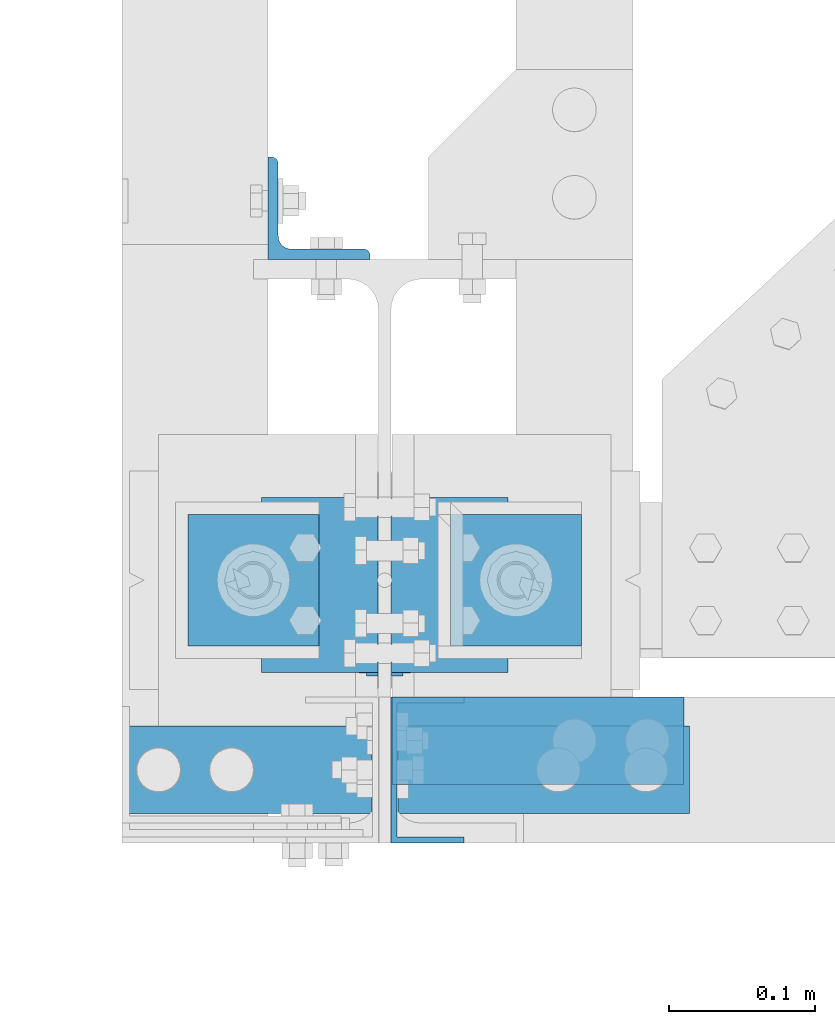
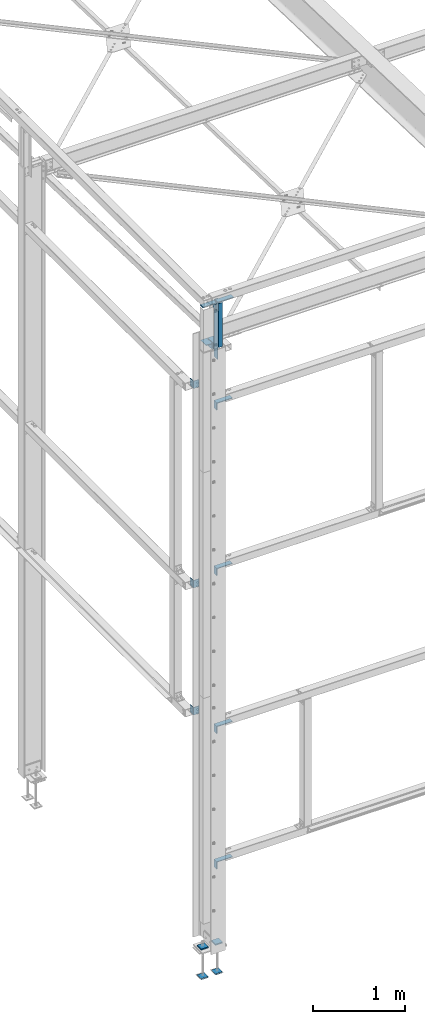
# One storey, part 60 of 496: 16 beams, 13 elements without a shape of their own.
"""IFC2X3 building model written with IfcOpenShell, lengths in millimetres."""

from ifc_helpers import new_model, si_unit, frame, origin_with_axes, origin_2d_with_axis, place, context, subcontext, project, spatial, polyline, l_section, u_section, outline, extrude, boolean, clip, halfspace, material, type_object, element, aggregate, save


model = new_model("IFC2X3")

# Units and contexts
model_context = context("Model", 3, precision=1e-05, world=origin_with_axes())
body_context = subcontext(model_context, "Body", "Model", "MODEL_VIEW")
ifc_project = project(units=[si_unit("LENGTHUNIT", "METRE", prefix="MILLI"), si_unit("AREAUNIT", "SQUARE_METRE"), si_unit("VOLUMEUNIT", "CUBIC_METRE"), si_unit("MASSUNIT", "GRAM", prefix="KILO"), si_unit("TIMEUNIT", "SECOND"), si_unit("PLANEANGLEUNIT", "RADIAN"), si_unit("SOLIDANGLEUNIT", "STERADIAN"), si_unit("THERMODYNAMICTEMPERATUREUNIT", "DEGREE_CELSIUS"), si_unit("LUMINOUSINTENSITYUNIT", "LUMEN")], contexts=[model_context])

# Site, building, storey
site_placement = place(None, origin_with_axes())
site = spatial("IfcSite", under=ifc_project, at=site_placement, CompositionType="ELEMENT")
building_placement = place(site_placement, origin_with_axes())
building = spatial("IfcBuilding", under=site, at=building_placement, Name="Undefined", CompositionType="ELEMENT")
storey_placement = place(building_placement, origin_with_axes())
storey = spatial("IfcBuildingStorey", under=building, at=storey_placement, Name="Undefined", CompositionType="ELEMENT", Elevation=0.0)

# Assembly, beam
assembly_1_placement = place(storey_placement, origin_with_axes())
assembly_1 = element("IfcElementAssembly", 1, at=assembly_1_placement, inside=storey, AssemblyPlace="NOTDEFINED", PredefinedType="NOTDEFINED")
ifc_material = material(Name="Undefined/S235-E24")
beam_type_1 = type_object("IfcBeamType", PredefinedType="NOTDEFINED")
beam_1_placement = place(assembly_1_placement, frame((-44.4999999998312, -64.3677476422468, 7811.91124581093), z_axis=(0.0, -0.031410887010906, -0.999506556345274), x_axis=(0.0, 0.999506556345274, -0.0314108870109058)))
beam_1 = element("IfcBeam", 2, at=beam_1_placement, type_object=beam_type_1, material=ifc_material, context=body_context, shape_type="SweptSolid", body=[
    extrude(l_section(Depth=80.0, Width=80.0, Thickness=8.0, FilletRadius=10.0, EdgeRadius=5.0, at=origin_2d_with_axis()), frame((120.0, 0.0, 0.0), z_axis=(-1.0, 0.0, 0.0), x_axis=(0.0, -1.0, 0.0)), (0.0, 0.0, 1.0), 120.0),
])
aggregate(assembly_1, [beam_1])

assembly_2_placement = place(storey_placement, origin_with_axes())
assembly_2 = element("IfcElementAssembly", 3, at=assembly_2_placement, inside=storey, AssemblyPlace="NOTDEFINED", PredefinedType="NOTDEFINED")
beam_2_placement = place(assembly_2_placement, frame((44.4999999998313, 55.5730378710973, 7808.14189965114), z_axis=(0.0, -0.031410887010906, -0.999506556345274), x_axis=(0.0, -0.999506556345276, 0.031410887010852)))
beam_2 = element("IfcBeam", 4, at=beam_2_placement, type_object=beam_type_1, material=ifc_material, context=body_context, shape_type="SweptSolid", body=[
    extrude(l_section(Depth=80.0, Width=80.0, Thickness=8.0, FilletRadius=10.0, EdgeRadius=5.0, at=origin_2d_with_axis()), frame((120.0, 0.0, 0.0), z_axis=(-1.0, 0.0, 0.0), x_axis=(0.0, -1.0, 0.0)), (0.0, 0.0, 1.0), 120.0),
])
aggregate(assembly_2, [beam_2])

assembly_3_placement = place(storey_placement, origin_with_axes())
assembly_3 = element("IfcElementAssembly", 5, at=assembly_3_placement, inside=storey, AssemblyPlace="NOTDEFINED", PredefinedType="NOTDEFINED")
beam_type_2 = type_object("IfcBeamType", PredefinedType="NOTDEFINED")
beam_3_placement = place(assembly_3_placement, frame((29.3000008447586, -130.000001617315, 8445.00161512511), z_axis=(0.0, 1.0, 0.0), x_axis=(0.0, 0.0, -1.0)))
beam_3 = element("IfcBeam", 6, at=beam_3_placement, type_object=beam_type_2, material=ifc_material, context=body_context, shape_type="CSG", body=[
    boolean("DIFFERENCE", extrude(u_section(Depth=100.0, FlangeWidth=50.0, WebThickness=4.0, FlangeThickness=4.0, at=origin_2d_with_axis()), frame((754.998684463203, 0.0, 0.0), z_axis=(-1.0, 0.0, 0.0), x_axis=(0.0, -1.0, 0.0)), (0.0, 0.0, 1.0), 755.0), extrude(outline(polyline([(0.0, 0.0), (20.0, 0.0), (19.9999939326024, 170.0), (-6.06739681074941e-06, 170.0), (0.0, 0.0)])), frame((584.998600811777, -27.5000000000036, -50.0000000000008), z_axis=(0.0, 1.0, 0.0), x_axis=(0.0, 0.0, 1.0)), (0.0, 0.0, 1.0), 55.0)),
])
aggregate(assembly_3, [beam_3])

assembly_4_placement = place(storey_placement, origin_with_axes())
assembly_4 = element("IfcElementAssembly", 7, at=assembly_4_placement, inside=storey, AssemblyPlace="NOTDEFINED", PredefinedType="NOTDEFINED")
beam_type_3 = type_object("IfcBeamType", PredefinedType="NOTDEFINED")
beam_4_placement = place(assembly_4_placement, frame((-45.0000013899306, 255.000037100011, 7200.00005189506), z_axis=(0.0, 1.0, 0.0), x_axis=(0.0, 0.0, -1.0)))
beam_4 = element("IfcBeam", 8, at=beam_4_placement, type_object=beam_type_3, material=ifc_material, context=body_context, shape_type="SweptSolid", body=[
    extrude(l_section(Depth=70.0, Width=70.0, Thickness=7.0, FilletRadius=9.0, EdgeRadius=4.5, at=origin_2d_with_axis()), frame((100.000000000021, 5.72981662116945e-11, -4.09272615797818e-12), z_axis=(-1.0, 0.0, 0.0), x_axis=(0.0, -1.0, 0.0)), (0.0, 0.0, 1.0), 100.0),
])
aggregate(assembly_4, [beam_4])

assembly_5_placement = place(storey_placement, origin_with_axes())
assembly_5 = element("IfcElementAssembly", 9, at=assembly_5_placement, inside=storey, AssemblyPlace="NOTDEFINED", PredefinedType="NOTDEFINED")
beam_5_placement = place(assembly_5_placement, frame((-45.0000013899306, 254.999986479989, 2860.0000275648), z_axis=(0.0, 1.0, 0.0), x_axis=(0.0, 0.0, -1.0)))
beam_5 = element("IfcBeam", 10, at=beam_5_placement, type_object=beam_type_3, material=ifc_material, context=body_context, shape_type="SweptSolid", body=[
    extrude(l_section(Depth=70.0, Width=70.0, Thickness=7.0, FilletRadius=9.0, EdgeRadius=4.5, at=origin_2d_with_axis()), frame((100.000000000021, 5.72981662116945e-11, -4.09272615797818e-12), z_axis=(-1.0, 0.0, 0.0), x_axis=(0.0, -1.0, 0.0)), (0.0, 0.0, 1.0), 100.0),
])
aggregate(assembly_5, [beam_5])

assembly_6_placement = place(storey_placement, origin_with_axes())
assembly_6 = element("IfcElementAssembly", 11, at=assembly_6_placement, inside=storey, AssemblyPlace="NOTDEFINED", PredefinedType="NOTDEFINED")
beam_6_placement = place(assembly_6_placement, frame((-45.0000013899306, 255.0, 4550.00002768), z_axis=(0.0, 1.0, 0.0), x_axis=(0.0, 0.0, -1.0)))
beam_6 = element("IfcBeam", 12, at=beam_6_placement, type_object=beam_type_3, material=ifc_material, context=body_context, shape_type="SweptSolid", body=[
    extrude(l_section(Depth=70.0, Width=70.0, Thickness=7.0, FilletRadius=9.0, EdgeRadius=4.5, at=origin_2d_with_axis()), frame((100.000000000021, 5.72981662116945e-11, -4.09272615797818e-12), z_axis=(-1.0, 0.0, 0.0), x_axis=(0.0, -1.0, 0.0)), (0.0, 0.0, 1.0), 100.0),
])
aggregate(assembly_6, [beam_6])

assembly_7_placement = place(storey_placement, origin_with_axes())
assembly_7 = element("IfcElementAssembly", 13, at=assembly_7_placement, inside=storey, AssemblyPlace="NOTDEFINED", PredefinedType="NOTDEFINED")
beam_type_4 = type_object("IfcBeamType", PredefinedType="NOTDEFINED")
beam_7_placement = place(assembly_7_placement, frame((-109.0000001905, -100.00000666075, 8400.0), z_axis=(-1.0, 0.0, 0.0), x_axis=(0.0, -1.0, 0.0)))
beam_7 = element("IfcBeam", 14, at=beam_7_placement, type_object=beam_type_4, material=ifc_material, context=body_context, shape_type="Clipping", body=[
    clip(extrude(l_section(Depth=200.0, Width=100.0, Thickness=10.0, FilletRadius=15.0, EdgeRadius=7.5, at=origin_2d_with_axis()), frame((60.0, 0.0, 0.0), z_axis=(-1.0, 0.0, 0.0), x_axis=(0.0, -1.0, 0.0)), (0.0, 0.0, 1.0), 60.0), halfspace(frame((59.999999991848, 50.0000000000018, 70.9999987405053), z_axis=(0.0, 0.0, 1.0), x_axis=(0.0, -1.0, 0.0)), False)),
])
aggregate(assembly_7, [beam_7])

assembly_8_placement = place(storey_placement, origin_with_axes())
assembly_8 = element("IfcElementAssembly", 15, at=assembly_8_placement, inside=storey, AssemblyPlace="NOTDEFINED", PredefinedType="NOTDEFINED")
beam_8_placement = place(assembly_8_placement, frame((109.000003088513, -160.000007080776, 8400.0), z_axis=(1.0, 0.0, 0.0), x_axis=(0.0, 1.0, 0.0)))
beam_8 = element("IfcBeam", 16, at=beam_8_placement, type_object=beam_type_4, material=ifc_material, context=body_context, shape_type="SweptSolid", body=[
    extrude(l_section(Depth=200.0, Width=100.0, Thickness=10.0, FilletRadius=15.0, EdgeRadius=7.5, at=origin_2d_with_axis()), frame((60.0, 0.0, 0.0), z_axis=(-1.0, 0.0, 0.0), x_axis=(0.0, -1.0, 0.0)), (0.0, 0.0, 1.0), 60.0),
])
aggregate(assembly_8, [beam_8])

assembly_9_placement = place(storey_placement, origin_with_axes())
assembly_9 = element("IfcElementAssembly", 17, at=assembly_9_placement, inside=storey, AssemblyPlace="NOTDEFINED", PredefinedType="NOTDEFINED")
beam_9_placement = place(assembly_9_placement, frame((105.000003086694, -140.000007080964, 950.0), z_axis=(1.0, 0.0, 0.0), x_axis=(0.0, 1.0, 0.0)))
beam_9 = element("IfcBeam", 18, at=beam_9_placement, type_object=beam_type_4, material=ifc_material, context=body_context, shape_type="SweptSolid", body=[
    extrude(l_section(Depth=200.0, Width=100.0, Thickness=10.0, FilletRadius=15.0, EdgeRadius=7.5, at=origin_2d_with_axis()), frame((60.0, 0.0, 0.0), z_axis=(-1.0, 0.0, 0.0), x_axis=(0.0, -1.0, 0.0)), (0.0, 0.0, 1.0), 60.0),
])
aggregate(assembly_9, [beam_9])

assembly_10_placement = place(storey_placement, origin_with_axes())
assembly_10 = element("IfcElementAssembly", 19, at=assembly_10_placement, inside=storey, AssemblyPlace="NOTDEFINED", PredefinedType="NOTDEFINED")
beam_10_placement = place(assembly_10_placement, frame((105.000003086694, -140.000007080964, 2750.0), z_axis=(1.0, 0.0, 0.0), x_axis=(0.0, 1.0, 0.0)))
beam_10 = element("IfcBeam", 20, at=beam_10_placement, type_object=beam_type_4, material=ifc_material, context=body_context, shape_type="SweptSolid", body=[
    extrude(l_section(Depth=200.0, Width=100.0, Thickness=10.0, FilletRadius=15.0, EdgeRadius=7.5, at=origin_2d_with_axis()), frame((60.0, 0.0, 0.0), z_axis=(-1.0, 0.0, 0.0), x_axis=(0.0, -1.0, 0.0)), (0.0, 0.0, 1.0), 60.0),
])
aggregate(assembly_10, [beam_10])

assembly_11_placement = place(storey_placement, origin_with_axes())
assembly_11 = element("IfcElementAssembly", 21, at=assembly_11_placement, inside=storey, AssemblyPlace="NOTDEFINED", PredefinedType="NOTDEFINED")
beam_11_placement = place(assembly_11_placement, frame((105.000003086694, -140.000007080964, 4850.0), z_axis=(1.0, 0.0, 0.0), x_axis=(0.0, 1.0, 0.0)))
beam_11 = element("IfcBeam", 22, at=beam_11_placement, type_object=beam_type_4, material=ifc_material, context=body_context, shape_type="SweptSolid", body=[
    extrude(l_section(Depth=200.0, Width=100.0, Thickness=10.0, FilletRadius=15.0, EdgeRadius=7.5, at=origin_2d_with_axis()), frame((60.0, 0.0, 0.0), z_axis=(-1.0, 0.0, 0.0), x_axis=(0.0, -1.0, 0.0)), (0.0, 0.0, 1.0), 60.0),
])
aggregate(assembly_11, [beam_11])

assembly_12_placement = place(storey_placement, origin_with_axes())
assembly_12 = element("IfcElementAssembly", 23, at=assembly_12_placement, inside=storey, AssemblyPlace="NOTDEFINED", PredefinedType="NOTDEFINED")
beam_12_placement = place(assembly_12_placement, frame((105.000003086694, -140.000007080964, 7050.0), z_axis=(1.0, 0.0, 0.0), x_axis=(0.0, 1.0, 0.0)))
beam_12 = element("IfcBeam", 24, at=beam_12_placement, type_object=beam_type_4, material=ifc_material, context=body_context, shape_type="SweptSolid", body=[
    extrude(l_section(Depth=200.0, Width=100.0, Thickness=10.0, FilletRadius=15.0, EdgeRadius=7.5, at=origin_2d_with_axis()), frame((60.0, 0.0, 0.0), z_axis=(-1.0, 0.0, 0.0), x_axis=(0.0, -1.0, 0.0)), (0.0, 0.0, 1.0), 60.0),
])
aggregate(assembly_12, [beam_12])

# Assembly, beams
assembly_13_placement = place(storey_placement, origin_with_axes())
assembly_13 = element("IfcElementAssembly", 25, at=assembly_13_placement, inside=storey, Name="PS24", AssemblyPlace="NOTDEFINED", PredefinedType="NOTDEFINED")
beam_type_5 = type_object("IfcBeamType", PredefinedType="NOTDEFINED")
beam_13_placement = place(assembly_13_placement, frame((-45.0028495552906, -45.0, -177.5), z_axis=(0.0, 0.0, 1.0), x_axis=(0.0, 1.0, 0.0)))
beam_13 = element("IfcBeam", 26, at=beam_13_placement, type_object=beam_type_5, material=ifc_material, context=body_context, shape_type="SweptSolid", body=[
    extrude(outline(polyline([(0.0, 0.0), (90.0, 0.0), (90.0, 90.0), (0.0, 90.0), (0.0, 0.0)])), frame((0.0, 0.0, -7.5), z_axis=(0.0, 0.0, 1.0), x_axis=(1.0, 0.0, 0.0)), (0.0, 0.0, 1.0), 15.0),
])
beam_14_placement = place(assembly_13_placement, frame((134.997150444709, -45.0, -177.5), z_axis=(0.0, 0.0, 1.0), x_axis=(0.0, 1.0, 0.0)))
beam_14 = element("IfcBeam", 27, at=beam_14_placement, type_object=beam_type_5, material=ifc_material, context=body_context, shape_type="SweptSolid", body=[
    extrude(outline(polyline([(0.0, 0.0), (90.0, 0.0), (90.0, 90.0), (0.0, 90.0), (0.0, 0.0)])), frame((0.0, 0.0, -7.5), z_axis=(0.0, 0.0, 1.0), x_axis=(1.0, 0.0, 0.0)), (0.0, 0.0, 1.0), 15.0),
])
beam_15_placement = place(assembly_13_placement, frame((-45.0028495552906, -45.0, -572.5), z_axis=(0.0, 0.0, 1.0), x_axis=(0.0, 1.0, 0.0)))
beam_15 = element("IfcBeam", 28, at=beam_15_placement, type_object=beam_type_5, material=ifc_material, context=body_context, shape_type="SweptSolid", body=[
    extrude(outline(polyline([(0.0, 0.0), (90.0, 0.0), (90.0, 90.0), (0.0, 90.0), (0.0, 0.0)])), frame((0.0, 0.0, -7.5), z_axis=(0.0, 0.0, 1.0), x_axis=(1.0, 0.0, 0.0)), (0.0, 0.0, 1.0), 15.0),
])
beam_16_placement = place(assembly_13_placement, frame((134.997150444709, -45.0, -572.5), z_axis=(0.0, 0.0, 1.0), x_axis=(0.0, 1.0, 0.0)))
beam_16 = element("IfcBeam", 29, at=beam_16_placement, type_object=beam_type_5, material=ifc_material, context=body_context, shape_type="SweptSolid", body=[
    extrude(outline(polyline([(0.0, 0.0), (90.0, 0.0), (90.0, 90.0), (0.0, 90.0), (0.0, 0.0)])), frame((0.0, 0.0, -7.5), z_axis=(0.0, 0.0, 1.0), x_axis=(1.0, 0.0, 0.0)), (0.0, 0.0, 1.0), 15.0),
])
aggregate(assembly_13, [beam_13, beam_14, beam_15, beam_16])

save(model, "model.ifc")
